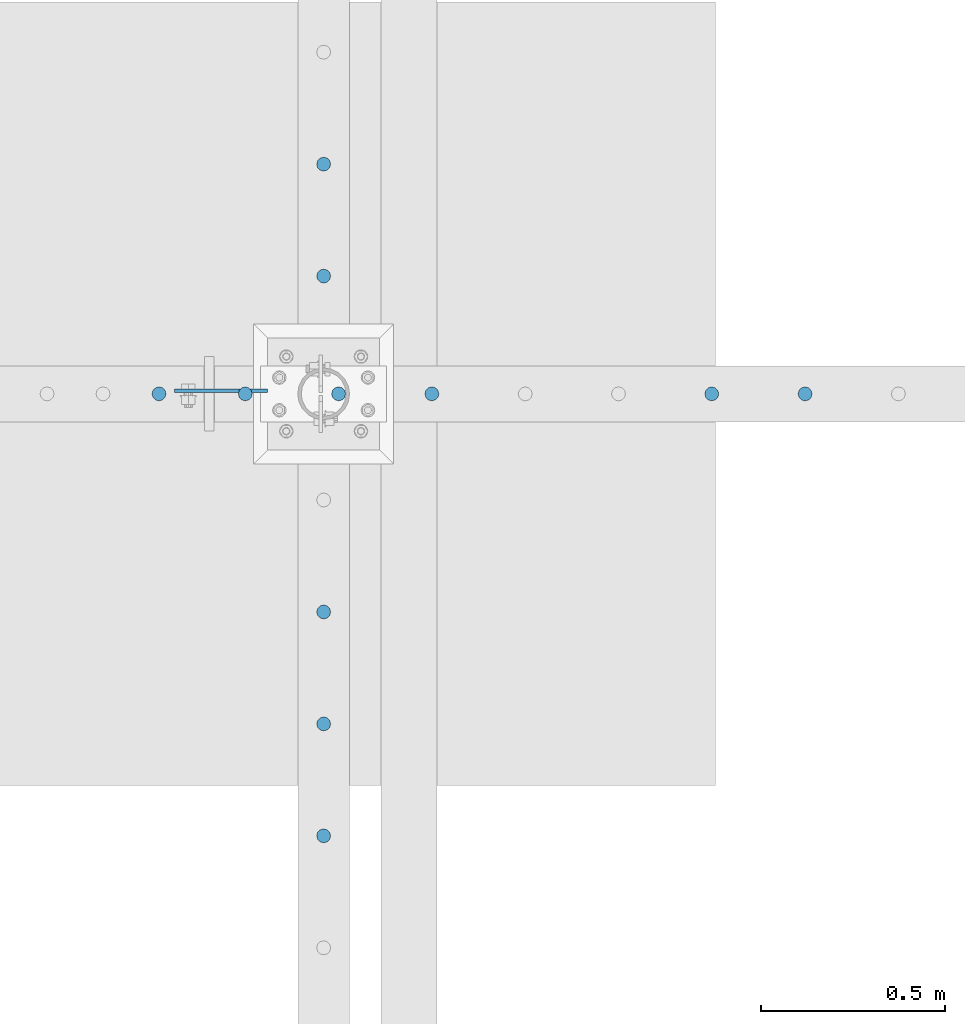
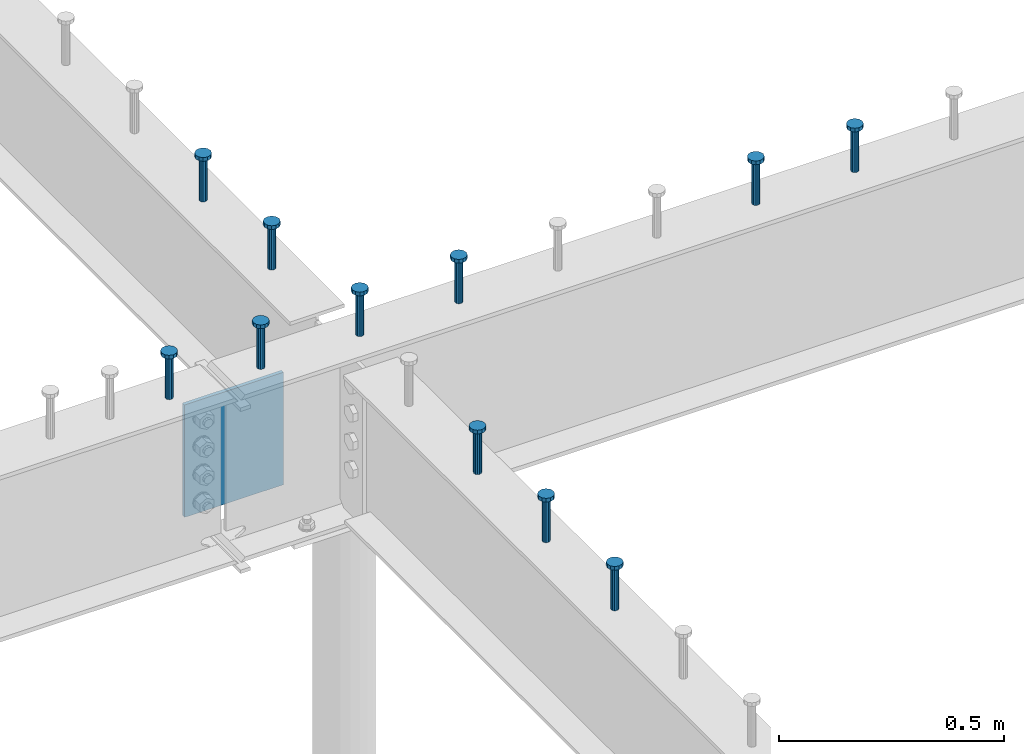
# One storey, part 165 of 975: 12 columns.
"""IFC2X3 building model written with IfcOpenShell, lengths in millimetres."""

import ifcopenshell
import ifcopenshell.guid

model = None  # the IFC model being written
_history = None  # IfcOwnerHistory: only IFC2X3 demands one
_inside = {}  # id of a spatial element -> (the spatial element, [elements in it])
_under = {}  # id of a project, library or spatial element -> (it, [spatial elements below it])
_declared = {}  # id of a project -> (the project, [libraries it declares])
_typed = {}  # id of a type object -> (the type object, [elements of that type])
_made_of = {}  # id of a material, layer set ... -> (it, [elements and type objects made of it])


def new_model(schema):
    """Start an empty IFC model of exactly this schema.

    Asked for "IFC4X3", IfcOpenShell would pick the latest addendum, in which some entities
    have other attributes; the version numbers below select the first issue.
    IFC2X3 requires an IfcOwnerHistory on every rooted entity: one is made here for all.
    """
    global model, _history
    if schema == "IFC4X3":
        model = ifcopenshell.file(schema_version=(4, 3, 0, 0))
    else:
        model = ifcopenshell.file(schema=schema)
    _inside.clear()
    _under.clear()
    _declared.clear()
    _typed.clear()
    _made_of.clear()
    _history = None
    if model.schema == "IFC2X3":
        org = make("IfcOrganization", Name="unknown")
        user = make(
            "IfcPersonAndOrganization",
            ThePerson=make("IfcPerson", FamilyName="unknown"),
            TheOrganization=org,
        )
        app = make(
            "IfcApplication",
            ApplicationDeveloper=org,
            Version="unknown",
            ApplicationFullName="unknown",
            ApplicationIdentifier="unknown",
        )
        _history = make(
            "IfcOwnerHistory",
            OwningUser=user,
            OwningApplication=app,
            ChangeAction="ADDED",
            CreationDate=0,
        )
    return model


def make(cls, **values):
    """One entity of the class cls with the attributes given. An attribute that is None is left unset."""
    return model.create_entity(
        cls, **{name: value for name, value in values.items() if value is not None}
    )


def rooted(cls, **values):
    """An entity with a GlobalId (a new one), such as an element, a storey or a relation."""
    return make(cls, GlobalId=ifcopenshell.guid.new(), OwnerHistory=_history, **values)


def si_unit(unit_type, name, prefix=None):
    """IfcSIUnit, for example si_unit("LENGTHUNIT", "METRE", prefix="MILLI")."""
    return make("IfcSIUnit", UnitType=unit_type, Prefix=prefix, Name=name)


def assignment(units):
    """IfcUnitAssignment: the units of a project."""
    return None if units is None else make("IfcUnitAssignment", Units=units)


def point(xyz):
    """IfcCartesianPoint."""
    return None if xyz is None else make("IfcCartesianPoint", Coordinates=xyz)


def direction(xyz):
    """IfcDirection."""
    return None if xyz is None else make("IfcDirection", DirectionRatios=xyz)


def frame(location, z_axis=None, x_axis=None):
    """IfcAxis2Placement3D, a coordinate frame: its origin and axes. An axis left out is left unset."""
    return make(
        "IfcAxis2Placement3D",
        Location=point(location),
        Axis=direction(z_axis),
        RefDirection=direction(x_axis),
    )


def origin_with_axes():
    """The frame at (0, 0, 0) with the z axis (0, 0, 1) and the x axis (1, 0, 0) written out."""
    return frame((0.0, 0.0, 0.0), z_axis=(0.0, 0.0, 1.0), x_axis=(1.0, 0.0, 0.0))


def place(relative_to, where):
    """IfcLocalPlacement: puts the frame where relative to a parent placement (None: the world)."""
    return make(
        "IfcLocalPlacement", PlacementRelTo=relative_to, RelativePlacement=where
    )


def context(
    kind, dimensions, precision=None, world=None, true_north=None, identifier=None
):
    """IfcGeometricRepresentationContext, for example the 3D "Model" context."""
    return make(
        "IfcGeometricRepresentationContext",
        ContextIdentifier=identifier,
        ContextType=kind,
        CoordinateSpaceDimension=dimensions,
        Precision=precision,
        WorldCoordinateSystem=world,
        TrueNorth=true_north,
    )


def subcontext(parent, identifier, kind, view, scale=None):
    """IfcGeometricRepresentationSubContext, for example "Body" below "Model"."""
    return make(
        "IfcGeometricRepresentationSubContext",
        ContextIdentifier=identifier,
        ContextType=kind,
        ParentContext=parent,
        TargetScale=scale,
        TargetView=view,
    )


def project(units=None, contexts=None):
    """IfcProject with its units and contexts."""
    return rooted(
        "IfcProject",
        Name="project",
        RepresentationContexts=contexts,
        UnitsInContext=assignment(units),
    )


def spatial(cls, under=None, at=None, **own):
    """A site, building, storey or space (cls), placed at a placement, below another one or the project."""
    s = rooted(cls, ObjectPlacement=at, **own)
    if under is not None:
        _under.setdefault(under.id(), (under, []))[1].append(s)
    return s


def faces_of(points, faces, orient=None, outer=None):
    """IfcFace entities. A face is a list of loops; a loop is a list of indices into points, from 0.

    orient and outer hold one flag for each loop. By default every Orientation is true, the
    first loop of a face is its IfcFaceOuterBound and the others are IfcFaceBound.
    """
    made = []
    for i, loops in enumerate(faces):
        bounds = []
        for j, loop in enumerate(loops):
            is_outer = j == 0 if outer is None else outer[i][j]
            bounds.append(
                make(
                    "IfcFaceOuterBound" if is_outer else "IfcFaceBound",
                    Bound=make("IfcPolyLoop", Polygon=[points[k] for k in loop]),
                    Orientation=True if orient is None else orient[i][j],
                )
            )
        made.append(make("IfcFace", Bounds=bounds))
    return made


def faceted_brep(points, faces, orient=None, outer=None, voids=None):
    """IfcFacetedBrep: a solid bounded by flat faces; with voids (closed shells), ...WithVoids."""
    shared = [point(p) for p in points]
    hull = make("IfcClosedShell", CfsFaces=faces_of(shared, faces, orient, outer))
    if voids is None:
        return make("IfcFacetedBrep", Outer=hull)
    return make(
        "IfcFacetedBrepWithVoids",
        Outer=hull,
        Voids=[
            make(cls, CfsFaces=faces_of(shared, fs, o, b)) for cls, fs, o, b in voids
        ],
    )


def shape(context_of_items, identifier, shape_type, items):
    """IfcShapeRepresentation: the items that make up one representation, for example the "Body"."""
    return make(
        "IfcShapeRepresentation",
        ContextOfItems=context_of_items,
        RepresentationIdentifier=identifier,
        RepresentationType=shape_type,
        Items=items,
    )


def material(Name=None, Category=None):
    """IfcMaterial."""
    return make("IfcMaterial", Name=Name, Category=Category)


def made_of(thing, what):
    """Note that an element or type object is made of a material, layer set ...; save() writes the relation."""
    if what is not None:
        _made_of.setdefault(what.id(), (what, []))[1].append(thing)
    return thing


def type_object(cls, material=None, **own):
    """A type object (cls), such as IfcWallType, which elements share."""
    return made_of(rooted(cls, **own), material)


def element(
    cls,
    number,
    at=None,
    inside=None,
    cuts=None,
    type_object=None,
    material=None,
    context=None,
    identifier="Body",
    shape_type=None,
    held_by="IfcProductDefinitionShape",
    body=None,
    shapes=None,
    **own,
):
    """One element of the class cls, such as IfcWall. Its Tag is "e" and its number.

    at: its placement. inside: the storey or other place that contains it. cuts: it is an
    opening in that element (IfcRelVoidsElement). A single representation is given by context,
    identifier, shape_type and body (its items); several are given by shapes. held_by: the class
    of the entity that holds the representations. save() writes the other relations.
    """
    e = rooted(cls, Tag="e%d" % number, ObjectPlacement=at, **own)
    if body is not None:
        shapes = [shape(context, identifier, shape_type, body)]
    if shapes is not None:
        e.Representation = make(held_by, Representations=shapes)
    if inside is not None:
        _inside.setdefault(inside.id(), (inside, []))[1].append(e)
    if cuts is not None:
        rooted(
            "IfcRelVoidsElement", RelatingBuildingElement=cuts, RelatedOpeningElement=e
        )
    if type_object is not None:
        _typed.setdefault(type_object.id(), (type_object, []))[1].append(e)
    return made_of(e, material)


def aggregate(whole, parts):
    """IfcRelAggregates: a whole, such as a stair, and the parts it consists of."""
    return rooted("IfcRelAggregates", RelatingObject=whole, RelatedObjects=parts)


def save(model, path):
    """Write the relations noted so far, then the file.

    IfcRelAggregates (storeys below a building ...), IfcRelContainedInSpatialStructure (elements
    in a storey), IfcRelDefinesByType, IfcRelAssociatesMaterial and IfcRelDeclares: one each for
    every whole, place, type object, material and project.
    """
    for whole, parts in _under.values():
        aggregate(whole, parts)
    for where, things in _inside.values():
        rooted(
            "IfcRelContainedInSpatialStructure",
            RelatedElements=things,
            RelatingStructure=where,
        )
    for kind, things in _typed.values():
        rooted("IfcRelDefinesByType", RelatedObjects=things, RelatingType=kind)
    for what, things in _made_of.values():
        rooted("IfcRelAssociatesMaterial", RelatedObjects=things, RelatingMaterial=what)
    for by, libraries in _declared.values():
        rooted("IfcRelDeclares", RelatingContext=by, RelatedDefinitions=libraries)
    model.write(path)


model = new_model("IFC2X3")

# Units and contexts
model_context = context("Model", 3, precision=1e-05, world=origin_with_axes())
body_context = subcontext(model_context, "Body", "Model", "MODEL_VIEW")
ifc_project = project(units=[si_unit("LENGTHUNIT", "METRE", prefix="MILLI"), si_unit("AREAUNIT", "SQUARE_METRE"), si_unit("VOLUMEUNIT", "CUBIC_METRE"), si_unit("MASSUNIT", "GRAM", prefix="KILO"), si_unit("TIMEUNIT", "SECOND"), si_unit("PLANEANGLEUNIT", "RADIAN"), si_unit("SOLIDANGLEUNIT", "STERADIAN"), si_unit("THERMODYNAMICTEMPERATUREUNIT", "DEGREE_CELSIUS"), si_unit("LUMINOUSINTENSITYUNIT", "LUMEN")], contexts=[model_context])

# Site, building, storey
site_placement = place(None, origin_with_axes())
site = spatial("IfcSite", under=ifc_project, at=site_placement, CompositionType="ELEMENT")
building_placement = place(site_placement, origin_with_axes())
building = spatial("IfcBuilding", under=site, at=building_placement, Name="Undefined", CompositionType="ELEMENT")
storey_placement = place(building_placement, origin_with_axes())
storey = spatial("IfcBuildingStorey", under=building, at=storey_placement, Name="Undefined", CompositionType="ELEMENT", Elevation=0.0)

# Columns
ifc_material_1 = material(Name="STEEL/A108")
column_type_1 = type_object("IfcColumnType", Name="STUD_3/4-DIA", PredefinedType="NOTDEFINED")
column_1_placement = place(storey_placement, frame((8229.66627141015, 14017.625, 3937.0), z_axis=(0.0, 1.0, 0.0), x_axis=(0.0, 0.0, 1.0)))
element("IfcColumn", 1, at=column_1_placement, inside=storey, type_object=column_type_1, material=ifc_material_1, ObjectType="STUD_3/4-DIA", context=body_context, shape_type="Brep", body=[
    faceted_brep([(0.0, -9.52000045776367, 0.0), (0.0, -8.25, -4.76000022888184), (115.57, -8.25, -4.76000022888184), (115.57, -9.52000045776367, 0.0), (0.0, -4.76000022888184, -8.25), (115.57, -4.76000022888184, -8.25), (0.0, 0.0, -9.52000045776367), (115.57, 0.0, -9.52000045776367), (0.0, 4.76000022888184, -8.25), (115.57, 4.76000022888184, -8.25), (0.0, 8.25, -4.76000022888184), (115.57, 8.25, -4.76000022888184), (0.0, 9.52000045776367, 0.0), (115.57, 9.52000045776367, 0.0), (0.0, 8.25, 4.76000022888184), (115.57, 8.25, 4.76000022888184), (0.0, 4.76000022888184, 8.25), (115.57, 4.76000022888184, 8.25), (0.0, 0.0, 9.52000045776367), (115.57, 0.0, 9.52000045776367), (0.0, -4.76000022888184, 8.25), (115.57, -4.76000022888184, 8.25), (0.0, -8.25, 4.76000022888184), (115.57, -8.25, 4.76000022888184), (116.84, -16.5, -9.52000045776367), (116.84, -19.0499992370605, 0.0), (116.84, -9.52000045776367, -16.5), (116.84, 0.0, -19.0499992370605), (116.84, 9.52000045776367, -16.5), (116.84, 16.5, -9.52000045776367), (116.84, 19.0499992370605, 0.0), (116.84, 16.5, 9.52000045776367), (116.84, 9.52000045776367, 16.5), (116.84, 0.0, 19.0499992370605), (116.84, -9.52000045776367, 16.5), (116.84, -16.5, 9.52000045776367), (127.0, -16.5, -9.52000045776367), (127.0, -19.0499992370605, 0.0), (127.0, -9.52000045776367, -16.5), (127.0, 0.0, -19.0499992370605), (127.0, 9.52000045776367, -16.5), (127.0, 16.5, -9.52000045776367), (127.0, 19.0499992370605, 0.0), (127.0, 16.5, 9.52000045776367), (127.0, 9.52000045776367, 16.5), (127.0, 0.0, 19.0499992370605), (127.0, -9.52000045776367, 16.5), (127.0, -16.5, 9.52000045776367)], [[[0, 1, 2, 3]], [[1, 4, 5, 2]], [[4, 6, 7, 5]], [[6, 8, 9, 7]], [[8, 10, 11, 9]], [[10, 12, 13, 11]], [[12, 14, 15, 13]], [[14, 16, 17, 15]], [[16, 18, 19, 17]], [[18, 20, 21, 19]], [[20, 22, 23, 21]], [[22, 0, 3, 23]], [[22, 20, 18, 16, 14, 12, 10, 8, 6, 4, 1, 0]], [[3, 2, 24, 25]], [[2, 5, 26, 24]], [[5, 7, 27, 26]], [[7, 9, 28, 27]], [[9, 11, 29, 28]], [[11, 13, 30, 29]], [[13, 15, 31, 30]], [[15, 17, 32, 31]], [[17, 19, 33, 32]], [[19, 21, 34, 33]], [[21, 23, 35, 34]], [[23, 3, 25, 35]], [[25, 24, 36, 37]], [[24, 26, 38, 36]], [[26, 27, 39, 38]], [[27, 28, 40, 39]], [[28, 29, 41, 40]], [[29, 30, 42, 41]], [[30, 31, 43, 42]], [[31, 32, 44, 43]], [[32, 33, 45, 44]], [[33, 34, 46, 45]], [[34, 35, 47, 46]], [[35, 25, 37, 47]], [[38, 39, 40, 41, 42, 43, 44, 45, 46, 47, 37, 36]]]),
])
column_2_placement = place(storey_placement, frame((8229.66627141015, 13712.825, 3937.0), z_axis=(0.0, 1.0, 0.0), x_axis=(0.0, 0.0, 1.0)))
element("IfcColumn", 2, at=column_2_placement, inside=storey, type_object=column_type_1, material=ifc_material_1, ObjectType="STUD_3/4-DIA", context=body_context, shape_type="Brep", body=[
    faceted_brep([(0.0, -9.52000045776367, 0.0), (0.0, -8.25, -4.76000022888184), (115.57, -8.25, -4.76000022888184), (115.57, -9.52000045776367, 0.0), (0.0, -4.76000022888184, -8.25), (115.57, -4.76000022888184, -8.25), (0.0, 0.0, -9.52000045776367), (115.57, 0.0, -9.52000045776367), (0.0, 4.76000022888184, -8.25), (115.57, 4.76000022888184, -8.25), (0.0, 8.25, -4.76000022888184), (115.57, 8.25, -4.76000022888184), (0.0, 9.52000045776367, 0.0), (115.57, 9.52000045776367, 0.0), (0.0, 8.25, 4.76000022888184), (115.57, 8.25, 4.76000022888184), (0.0, 4.76000022888184, 8.25), (115.57, 4.76000022888184, 8.25), (0.0, 0.0, 9.52000045776367), (115.57, 0.0, 9.52000045776367), (0.0, -4.76000022888184, 8.25), (115.57, -4.76000022888184, 8.25), (0.0, -8.25, 4.76000022888184), (115.57, -8.25, 4.76000022888184), (116.84, -16.5, -9.52000045776367), (116.84, -19.0499992370605, 0.0), (116.84, -9.52000045776367, -16.5), (116.84, 0.0, -19.0499992370605), (116.84, 9.52000045776367, -16.5), (116.84, 16.5, -9.52000045776367), (116.84, 19.0499992370605, 0.0), (116.84, 16.5, 9.52000045776367), (116.84, 9.52000045776367, 16.5), (116.84, 0.0, 19.0499992370605), (116.84, -9.52000045776367, 16.5), (116.84, -16.5, 9.52000045776367), (127.0, -16.5, -9.52000045776367), (127.0, -19.0499992370605, 0.0), (127.0, -9.52000045776367, -16.5), (127.0, 0.0, -19.0499992370605), (127.0, 9.52000045776367, -16.5), (127.0, 16.5, -9.52000045776367), (127.0, 19.0499992370605, 0.0), (127.0, 16.5, 9.52000045776367), (127.0, 9.52000045776367, 16.5), (127.0, 0.0, 19.0499992370605), (127.0, -9.52000045776367, 16.5), (127.0, -16.5, 9.52000045776367)], [[[0, 1, 2, 3]], [[1, 4, 5, 2]], [[4, 6, 7, 5]], [[6, 8, 9, 7]], [[8, 10, 11, 9]], [[10, 12, 13, 11]], [[12, 14, 15, 13]], [[14, 16, 17, 15]], [[16, 18, 19, 17]], [[18, 20, 21, 19]], [[20, 22, 23, 21]], [[22, 0, 3, 23]], [[22, 20, 18, 16, 14, 12, 10, 8, 6, 4, 1, 0]], [[3, 2, 24, 25]], [[2, 5, 26, 24]], [[5, 7, 27, 26]], [[7, 9, 28, 27]], [[9, 11, 29, 28]], [[11, 13, 30, 29]], [[13, 15, 31, 30]], [[15, 17, 32, 31]], [[17, 19, 33, 32]], [[19, 21, 34, 33]], [[21, 23, 35, 34]], [[23, 3, 25, 35]], [[25, 24, 36, 37]], [[24, 26, 38, 36]], [[26, 27, 39, 38]], [[27, 28, 40, 39]], [[28, 29, 41, 40]], [[29, 30, 42, 41]], [[30, 31, 43, 42]], [[31, 32, 44, 43]], [[32, 33, 45, 44]], [[33, 34, 46, 45]], [[34, 35, 47, 46]], [[35, 25, 37, 47]], [[38, 39, 40, 41, 42, 43, 44, 45, 46, 47, 37, 36]]]),
])
column_3_placement = place(storey_placement, frame((8229.66627141015, 12798.425, 3937.0), z_axis=(0.0, 1.0, 0.0), x_axis=(0.0, 0.0, 1.0)))
element("IfcColumn", 3, at=column_3_placement, inside=storey, type_object=column_type_1, material=ifc_material_1, ObjectType="STUD_3/4-DIA", context=body_context, shape_type="Brep", body=[
    faceted_brep([(0.0, -9.52000045776367, 0.0), (0.0, -8.25, -4.76000022888184), (115.57, -8.25, -4.76000022888184), (115.57, -9.52000045776367, 0.0), (0.0, -4.76000022888184, -8.25), (115.57, -4.76000022888184, -8.25), (0.0, 0.0, -9.52000045776367), (115.57, 0.0, -9.52000045776367), (0.0, 4.76000022888184, -8.25), (115.57, 4.76000022888184, -8.25), (0.0, 8.25, -4.76000022888184), (115.57, 8.25, -4.76000022888184), (0.0, 9.52000045776367, 0.0), (115.57, 9.52000045776367, 0.0), (0.0, 8.25, 4.76000022888184), (115.57, 8.25, 4.76000022888184), (0.0, 4.76000022888184, 8.25), (115.57, 4.76000022888184, 8.25), (0.0, 0.0, 9.52000045776367), (115.57, 0.0, 9.52000045776367), (0.0, -4.76000022888184, 8.25), (115.57, -4.76000022888184, 8.25), (0.0, -8.25, 4.76000022888184), (115.57, -8.25, 4.76000022888184), (116.84, -16.5, -9.52000045776367), (116.84, -19.0499992370605, 0.0), (116.84, -9.52000045776367, -16.5), (116.84, 0.0, -19.0499992370605), (116.84, 9.52000045776367, -16.5), (116.84, 16.5, -9.52000045776367), (116.84, 19.0499992370605, 0.0), (116.84, 16.5, 9.52000045776367), (116.84, 9.52000045776367, 16.5), (116.84, 0.0, 19.0499992370605), (116.84, -9.52000045776367, 16.5), (116.84, -16.5, 9.52000045776367), (127.0, -16.5, -9.52000045776367), (127.0, -19.0499992370605, 0.0), (127.0, -9.52000045776367, -16.5), (127.0, 0.0, -19.0499992370605), (127.0, 9.52000045776367, -16.5), (127.0, 16.5, -9.52000045776367), (127.0, 19.0499992370605, 0.0), (127.0, 16.5, 9.52000045776367), (127.0, 9.52000045776367, 16.5), (127.0, 0.0, 19.0499992370605), (127.0, -9.52000045776367, 16.5), (127.0, -16.5, 9.52000045776367)], [[[0, 1, 2, 3]], [[1, 4, 5, 2]], [[4, 6, 7, 5]], [[6, 8, 9, 7]], [[8, 10, 11, 9]], [[10, 12, 13, 11]], [[12, 14, 15, 13]], [[14, 16, 17, 15]], [[16, 18, 19, 17]], [[18, 20, 21, 19]], [[20, 22, 23, 21]], [[22, 0, 3, 23]], [[22, 20, 18, 16, 14, 12, 10, 8, 6, 4, 1, 0]], [[3, 2, 24, 25]], [[2, 5, 26, 24]], [[5, 7, 27, 26]], [[7, 9, 28, 27]], [[9, 11, 29, 28]], [[11, 13, 30, 29]], [[13, 15, 31, 30]], [[15, 17, 32, 31]], [[17, 19, 33, 32]], [[19, 21, 34, 33]], [[21, 23, 35, 34]], [[23, 3, 25, 35]], [[25, 24, 36, 37]], [[24, 26, 38, 36]], [[26, 27, 39, 38]], [[27, 28, 40, 39]], [[28, 29, 41, 40]], [[29, 30, 42, 41]], [[30, 31, 43, 42]], [[31, 32, 44, 43]], [[32, 33, 45, 44]], [[33, 34, 46, 45]], [[34, 35, 47, 46]], [[35, 25, 37, 47]], [[38, 39, 40, 41, 42, 43, 44, 45, 46, 47, 37, 36]]]),
])
column_4_placement = place(storey_placement, frame((8229.66627141015, 12493.625, 3937.0), z_axis=(0.0, 1.0, 0.0), x_axis=(0.0, 0.0, 1.0)))
element("IfcColumn", 4, at=column_4_placement, inside=storey, type_object=column_type_1, material=ifc_material_1, ObjectType="STUD_3/4-DIA", context=body_context, shape_type="Brep", body=[
    faceted_brep([(0.0, -9.52000045776367, 0.0), (0.0, -8.25, -4.76000022888184), (115.57, -8.25, -4.76000022888184), (115.57, -9.52000045776367, 0.0), (0.0, -4.76000022888184, -8.25), (115.57, -4.76000022888184, -8.25), (0.0, 0.0, -9.52000045776367), (115.57, 0.0, -9.52000045776367), (0.0, 4.76000022888184, -8.25), (115.57, 4.76000022888184, -8.25), (0.0, 8.25, -4.76000022888184), (115.57, 8.25, -4.76000022888184), (0.0, 9.52000045776367, 0.0), (115.57, 9.52000045776367, 0.0), (0.0, 8.25, 4.76000022888184), (115.57, 8.25, 4.76000022888184), (0.0, 4.76000022888184, 8.25), (115.57, 4.76000022888184, 8.25), (0.0, 0.0, 9.52000045776367), (115.57, 0.0, 9.52000045776367), (0.0, -4.76000022888184, 8.25), (115.57, -4.76000022888184, 8.25), (0.0, -8.25, 4.76000022888184), (115.57, -8.25, 4.76000022888184), (116.84, -16.5, -9.52000045776367), (116.84, -19.0499992370605, 0.0), (116.84, -9.52000045776367, -16.5), (116.84, 0.0, -19.0499992370605), (116.84, 9.52000045776367, -16.5), (116.84, 16.5, -9.52000045776367), (116.84, 19.0499992370605, 0.0), (116.84, 16.5, 9.52000045776367), (116.84, 9.52000045776367, 16.5), (116.84, 0.0, 19.0499992370605), (116.84, -9.52000045776367, 16.5), (116.84, -16.5, 9.52000045776367), (127.0, -16.5, -9.52000045776367), (127.0, -19.0499992370605, 0.0), (127.0, -9.52000045776367, -16.5), (127.0, 0.0, -19.0499992370605), (127.0, 9.52000045776367, -16.5), (127.0, 16.5, -9.52000045776367), (127.0, 19.0499992370605, 0.0), (127.0, 16.5, 9.52000045776367), (127.0, 9.52000045776367, 16.5), (127.0, 0.0, 19.0499992370605), (127.0, -9.52000045776367, 16.5), (127.0, -16.5, 9.52000045776367)], [[[0, 1, 2, 3]], [[1, 4, 5, 2]], [[4, 6, 7, 5]], [[6, 8, 9, 7]], [[8, 10, 11, 9]], [[10, 12, 13, 11]], [[12, 14, 15, 13]], [[14, 16, 17, 15]], [[16, 18, 19, 17]], [[18, 20, 21, 19]], [[20, 22, 23, 21]], [[22, 0, 3, 23]], [[22, 20, 18, 16, 14, 12, 10, 8, 6, 4, 1, 0]], [[3, 2, 24, 25]], [[2, 5, 26, 24]], [[5, 7, 27, 26]], [[7, 9, 28, 27]], [[9, 11, 29, 28]], [[11, 13, 30, 29]], [[13, 15, 31, 30]], [[15, 17, 32, 31]], [[17, 19, 33, 32]], [[19, 21, 34, 33]], [[21, 23, 35, 34]], [[23, 3, 25, 35]], [[25, 24, 36, 37]], [[24, 26, 38, 36]], [[26, 27, 39, 38]], [[27, 28, 40, 39]], [[28, 29, 41, 40]], [[29, 30, 42, 41]], [[30, 31, 43, 42]], [[31, 32, 44, 43]], [[32, 33, 45, 44]], [[33, 34, 46, 45]], [[34, 35, 47, 46]], [[35, 25, 37, 47]], [[38, 39, 40, 41, 42, 43, 44, 45, 46, 47, 37, 36]]]),
])
column_5_placement = place(storey_placement, frame((8229.66627141015, 12188.825, 3937.0), z_axis=(0.0, 1.0, 0.0), x_axis=(0.0, 0.0, 1.0)))
element("IfcColumn", 5, at=column_5_placement, inside=storey, type_object=column_type_1, material=ifc_material_1, ObjectType="STUD_3/4-DIA", context=body_context, shape_type="Brep", body=[
    faceted_brep([(0.0, -9.52000045776367, 0.0), (0.0, -8.25, -4.76000022888184), (115.57, -8.25, -4.76000022888184), (115.57, -9.52000045776367, 0.0), (0.0, -4.76000022888184, -8.25), (115.57, -4.76000022888184, -8.25), (0.0, 0.0, -9.52000045776367), (115.57, 0.0, -9.52000045776367), (0.0, 4.76000022888184, -8.25), (115.57, 4.76000022888184, -8.25), (0.0, 8.25, -4.76000022888184), (115.57, 8.25, -4.76000022888184), (0.0, 9.52000045776367, 0.0), (115.57, 9.52000045776367, 0.0), (0.0, 8.25, 4.76000022888184), (115.57, 8.25, 4.76000022888184), (0.0, 4.76000022888184, 8.25), (115.57, 4.76000022888184, 8.25), (0.0, 0.0, 9.52000045776367), (115.57, 0.0, 9.52000045776367), (0.0, -4.76000022888184, 8.25), (115.57, -4.76000022888184, 8.25), (0.0, -8.25, 4.76000022888184), (115.57, -8.25, 4.76000022888184), (116.84, -16.5, -9.52000045776367), (116.84, -19.0499992370605, 0.0), (116.84, -9.52000045776367, -16.5), (116.84, 0.0, -19.0499992370605), (116.84, 9.52000045776367, -16.5), (116.84, 16.5, -9.52000045776367), (116.84, 19.0499992370605, 0.0), (116.84, 16.5, 9.52000045776367), (116.84, 9.52000045776367, 16.5), (116.84, 0.0, 19.0499992370605), (116.84, -9.52000045776367, 16.5), (116.84, -16.5, 9.52000045776367), (127.0, -16.5, -9.52000045776367), (127.0, -19.0499992370605, 0.0), (127.0, -9.52000045776367, -16.5), (127.0, 0.0, -19.0499992370605), (127.0, 9.52000045776367, -16.5), (127.0, 16.5, -9.52000045776367), (127.0, 19.0499992370605, 0.0), (127.0, 16.5, 9.52000045776367), (127.0, 9.52000045776367, 16.5), (127.0, 0.0, 19.0499992370605), (127.0, -9.52000045776367, 16.5), (127.0, -16.5, 9.52000045776367)], [[[0, 1, 2, 3]], [[1, 4, 5, 2]], [[4, 6, 7, 5]], [[6, 8, 9, 7]], [[8, 10, 11, 9]], [[10, 12, 13, 11]], [[12, 14, 15, 13]], [[14, 16, 17, 15]], [[16, 18, 19, 17]], [[18, 20, 21, 19]], [[20, 22, 23, 21]], [[22, 0, 3, 23]], [[22, 20, 18, 16, 14, 12, 10, 8, 6, 4, 1, 0]], [[3, 2, 24, 25]], [[2, 5, 26, 24]], [[5, 7, 27, 26]], [[7, 9, 28, 27]], [[9, 11, 29, 28]], [[11, 13, 30, 29]], [[13, 15, 31, 30]], [[15, 17, 32, 31]], [[17, 19, 33, 32]], [[19, 21, 34, 33]], [[21, 23, 35, 34]], [[23, 3, 25, 35]], [[25, 24, 36, 37]], [[24, 26, 38, 36]], [[26, 27, 39, 38]], [[27, 28, 40, 39]], [[28, 29, 41, 40]], [[29, 30, 42, 41]], [[30, 31, 43, 42]], [[31, 32, 44, 43]], [[32, 33, 45, 44]], [[33, 34, 46, 45]], [[34, 35, 47, 46]], [[35, 25, 37, 47]], [[38, 39, 40, 41, 42, 43, 44, 45, 46, 47, 37, 36]]]),
])
column_6_placement = place(storey_placement, frame((9540.34595841014, 13392.15, 3937.0), z_axis=(0.0, 1.0, 0.0), x_axis=(0.0, 0.0, 1.0)))
element("IfcColumn", 6, at=column_6_placement, inside=storey, type_object=column_type_1, material=ifc_material_1, ObjectType="STUD_3/4-DIA", context=body_context, shape_type="Brep", body=[
    faceted_brep([(0.0, -9.52000045776367, 0.0), (0.0, -8.25, -4.76000022888184), (115.57, -8.25, -4.76000022888184), (115.57, -9.52000045776367, 0.0), (0.0, -4.76000022888184, -8.25), (115.57, -4.76000022888184, -8.25), (0.0, 0.0, -9.52000045776367), (115.57, 0.0, -9.52000045776367), (0.0, 4.76000022888184, -8.25), (115.57, 4.76000022888184, -8.25), (0.0, 8.25, -4.76000022888184), (115.57, 8.25, -4.76000022888184), (0.0, 9.52000045776367, 0.0), (115.57, 9.52000045776367, 0.0), (0.0, 8.25, 4.76000022888184), (115.57, 8.25, 4.76000022888184), (0.0, 4.76000022888184, 8.25), (115.57, 4.76000022888184, 8.25), (0.0, 0.0, 9.52000045776367), (115.57, 0.0, 9.52000045776367), (0.0, -4.76000022888184, 8.25), (115.57, -4.76000022888184, 8.25), (0.0, -8.25, 4.76000022888184), (115.57, -8.25, 4.76000022888184), (116.84, -16.5, -9.52000045776367), (116.84, -19.0499992370605, 0.0), (116.84, -9.52000045776367, -16.5), (116.84, 0.0, -19.0499992370605), (116.84, 9.52000045776367, -16.5), (116.84, 16.5, -9.52000045776367), (116.84, 19.0499992370605, 0.0), (116.84, 16.5, 9.52000045776367), (116.84, 9.52000045776367, 16.5), (116.84, 0.0, 19.0499992370605), (116.84, -9.52000045776367, 16.5), (116.84, -16.5, 9.52000045776367), (127.0, -16.5, -9.52000045776367), (127.0, -19.0499992370605, 0.0), (127.0, -9.52000045776367, -16.5), (127.0, 0.0, -19.0499992370605), (127.0, 9.52000045776367, -16.5), (127.0, 16.5, -9.52000045776367), (127.0, 19.0499992370605, 0.0), (127.0, 16.5, 9.52000045776367), (127.0, 9.52000045776367, 16.5), (127.0, 0.0, 19.0499992370605), (127.0, -9.52000045776367, 16.5), (127.0, -16.5, 9.52000045776367)], [[[0, 1, 2, 3]], [[1, 4, 5, 2]], [[4, 6, 7, 5]], [[6, 8, 9, 7]], [[8, 10, 11, 9]], [[10, 12, 13, 11]], [[12, 14, 15, 13]], [[14, 16, 17, 15]], [[16, 18, 19, 17]], [[18, 20, 21, 19]], [[20, 22, 23, 21]], [[22, 0, 3, 23]], [[22, 20, 18, 16, 14, 12, 10, 8, 6, 4, 1, 0]], [[3, 2, 24, 25]], [[2, 5, 26, 24]], [[5, 7, 27, 26]], [[7, 9, 28, 27]], [[9, 11, 29, 28]], [[11, 13, 30, 29]], [[13, 15, 31, 30]], [[15, 17, 32, 31]], [[17, 19, 33, 32]], [[19, 21, 34, 33]], [[21, 23, 35, 34]], [[23, 3, 25, 35]], [[25, 24, 36, 37]], [[24, 26, 38, 36]], [[26, 27, 39, 38]], [[27, 28, 40, 39]], [[28, 29, 41, 40]], [[29, 30, 42, 41]], [[30, 31, 43, 42]], [[31, 32, 44, 43]], [[32, 33, 45, 44]], [[33, 34, 46, 45]], [[34, 35, 47, 46]], [[35, 25, 37, 47]], [[38, 39, 40, 41, 42, 43, 44, 45, 46, 47, 37, 36]]]),
])
column_7_placement = place(storey_placement, frame((9286.34595841014, 13392.15, 3937.0), z_axis=(0.0, 1.0, 0.0), x_axis=(0.0, 0.0, 1.0)))
element("IfcColumn", 7, at=column_7_placement, inside=storey, type_object=column_type_1, material=ifc_material_1, ObjectType="STUD_3/4-DIA", context=body_context, shape_type="Brep", body=[
    faceted_brep([(0.0, -9.52000045776367, 0.0), (0.0, -8.25, -4.76000022888184), (115.57, -8.25, -4.76000022888184), (115.57, -9.52000045776367, 0.0), (0.0, -4.76000022888184, -8.25), (115.57, -4.76000022888184, -8.25), (0.0, 0.0, -9.52000045776367), (115.57, 0.0, -9.52000045776367), (0.0, 4.76000022888184, -8.25), (115.57, 4.76000022888184, -8.25), (0.0, 8.25, -4.76000022888184), (115.57, 8.25, -4.76000022888184), (0.0, 9.52000045776367, 0.0), (115.57, 9.52000045776367, 0.0), (0.0, 8.25, 4.76000022888184), (115.57, 8.25, 4.76000022888184), (0.0, 4.76000022888184, 8.25), (115.57, 4.76000022888184, 8.25), (0.0, 0.0, 9.52000045776367), (115.57, 0.0, 9.52000045776367), (0.0, -4.76000022888184, 8.25), (115.57, -4.76000022888184, 8.25), (0.0, -8.25, 4.76000022888184), (115.57, -8.25, 4.76000022888184), (116.84, -16.5, -9.52000045776367), (116.84, -19.0499992370605, 0.0), (116.84, -9.52000045776367, -16.5), (116.84, 0.0, -19.0499992370605), (116.84, 9.52000045776367, -16.5), (116.84, 16.5, -9.52000045776367), (116.84, 19.0499992370605, 0.0), (116.84, 16.5, 9.52000045776367), (116.84, 9.52000045776367, 16.5), (116.84, 0.0, 19.0499992370605), (116.84, -9.52000045776367, 16.5), (116.84, -16.5, 9.52000045776367), (127.0, -16.5, -9.52000045776367), (127.0, -19.0499992370605, 0.0), (127.0, -9.52000045776367, -16.5), (127.0, 0.0, -19.0499992370605), (127.0, 9.52000045776367, -16.5), (127.0, 16.5, -9.52000045776367), (127.0, 19.0499992370605, 0.0), (127.0, 16.5, 9.52000045776367), (127.0, 9.52000045776367, 16.5), (127.0, 0.0, 19.0499992370605), (127.0, -9.52000045776367, 16.5), (127.0, -16.5, 9.52000045776367)], [[[0, 1, 2, 3]], [[1, 4, 5, 2]], [[4, 6, 7, 5]], [[6, 8, 9, 7]], [[8, 10, 11, 9]], [[10, 12, 13, 11]], [[12, 14, 15, 13]], [[14, 16, 17, 15]], [[16, 18, 19, 17]], [[18, 20, 21, 19]], [[20, 22, 23, 21]], [[22, 0, 3, 23]], [[22, 20, 18, 16, 14, 12, 10, 8, 6, 4, 1, 0]], [[3, 2, 24, 25]], [[2, 5, 26, 24]], [[5, 7, 27, 26]], [[7, 9, 28, 27]], [[9, 11, 29, 28]], [[11, 13, 30, 29]], [[13, 15, 31, 30]], [[15, 17, 32, 31]], [[17, 19, 33, 32]], [[19, 21, 34, 33]], [[21, 23, 35, 34]], [[23, 3, 25, 35]], [[25, 24, 36, 37]], [[24, 26, 38, 36]], [[26, 27, 39, 38]], [[27, 28, 40, 39]], [[28, 29, 41, 40]], [[29, 30, 42, 41]], [[30, 31, 43, 42]], [[31, 32, 44, 43]], [[32, 33, 45, 44]], [[33, 34, 46, 45]], [[34, 35, 47, 46]], [[35, 25, 37, 47]], [[38, 39, 40, 41, 42, 43, 44, 45, 46, 47, 37, 36]]]),
])
column_8_placement = place(storey_placement, frame((8524.34595841014, 13392.15, 3937.0), z_axis=(0.0, 1.0, 0.0), x_axis=(0.0, 0.0, 1.0)))
element("IfcColumn", 8, at=column_8_placement, inside=storey, type_object=column_type_1, material=ifc_material_1, ObjectType="STUD_3/4-DIA", context=body_context, shape_type="Brep", body=[
    faceted_brep([(0.0, -9.52000045776367, 0.0), (0.0, -8.25, -4.76000022888184), (115.57, -8.25, -4.76000022888184), (115.57, -9.52000045776367, 0.0), (0.0, -4.76000022888184, -8.25), (115.57, -4.76000022888184, -8.25), (0.0, 0.0, -9.52000045776367), (115.57, 0.0, -9.52000045776367), (0.0, 4.76000022888184, -8.25), (115.57, 4.76000022888184, -8.25), (0.0, 8.25, -4.76000022888184), (115.57, 8.25, -4.76000022888184), (0.0, 9.52000045776367, 0.0), (115.57, 9.52000045776367, 0.0), (0.0, 8.25, 4.76000022888184), (115.57, 8.25, 4.76000022888184), (0.0, 4.76000022888184, 8.25), (115.57, 4.76000022888184, 8.25), (0.0, 0.0, 9.52000045776367), (115.57, 0.0, 9.52000045776367), (0.0, -4.76000022888184, 8.25), (115.57, -4.76000022888184, 8.25), (0.0, -8.25, 4.76000022888184), (115.57, -8.25, 4.76000022888184), (116.84, -16.5, -9.52000045776367), (116.84, -19.0499992370605, 0.0), (116.84, -9.52000045776367, -16.5), (116.84, 0.0, -19.0499992370605), (116.84, 9.52000045776367, -16.5), (116.84, 16.5, -9.52000045776367), (116.84, 19.0499992370605, 0.0), (116.84, 16.5, 9.52000045776367), (116.84, 9.52000045776367, 16.5), (116.84, 0.0, 19.0499992370605), (116.84, -9.52000045776367, 16.5), (116.84, -16.5, 9.52000045776367), (127.0, -16.5, -9.52000045776367), (127.0, -19.0499992370605, 0.0), (127.0, -9.52000045776367, -16.5), (127.0, 0.0, -19.0499992370605), (127.0, 9.52000045776367, -16.5), (127.0, 16.5, -9.52000045776367), (127.0, 19.0499992370605, 0.0), (127.0, 16.5, 9.52000045776367), (127.0, 9.52000045776367, 16.5), (127.0, 0.0, 19.0499992370605), (127.0, -9.52000045776367, 16.5), (127.0, -16.5, 9.52000045776367)], [[[0, 1, 2, 3]], [[1, 4, 5, 2]], [[4, 6, 7, 5]], [[6, 8, 9, 7]], [[8, 10, 11, 9]], [[10, 12, 13, 11]], [[12, 14, 15, 13]], [[14, 16, 17, 15]], [[16, 18, 19, 17]], [[18, 20, 21, 19]], [[20, 22, 23, 21]], [[22, 0, 3, 23]], [[22, 20, 18, 16, 14, 12, 10, 8, 6, 4, 1, 0]], [[3, 2, 24, 25]], [[2, 5, 26, 24]], [[5, 7, 27, 26]], [[7, 9, 28, 27]], [[9, 11, 29, 28]], [[11, 13, 30, 29]], [[13, 15, 31, 30]], [[15, 17, 32, 31]], [[17, 19, 33, 32]], [[19, 21, 34, 33]], [[21, 23, 35, 34]], [[23, 3, 25, 35]], [[25, 24, 36, 37]], [[24, 26, 38, 36]], [[26, 27, 39, 38]], [[27, 28, 40, 39]], [[28, 29, 41, 40]], [[29, 30, 42, 41]], [[30, 31, 43, 42]], [[31, 32, 44, 43]], [[32, 33, 45, 44]], [[33, 34, 46, 45]], [[34, 35, 47, 46]], [[35, 25, 37, 47]], [[38, 39, 40, 41, 42, 43, 44, 45, 46, 47, 37, 36]]]),
])
column_9_placement = place(storey_placement, frame((8270.34595841014, 13392.15, 3937.0), z_axis=(0.0, 1.0, 0.0), x_axis=(0.0, 0.0, 1.0)))
element("IfcColumn", 9, at=column_9_placement, inside=storey, type_object=column_type_1, material=ifc_material_1, ObjectType="STUD_3/4-DIA", context=body_context, shape_type="Brep", body=[
    faceted_brep([(0.0, -9.52000045776367, 0.0), (0.0, -8.25, -4.76000022888184), (115.57, -8.25, -4.76000022888184), (115.57, -9.52000045776367, 0.0), (0.0, -4.76000022888184, -8.25), (115.57, -4.76000022888184, -8.25), (0.0, 0.0, -9.52000045776367), (115.57, 0.0, -9.52000045776367), (0.0, 4.76000022888184, -8.25), (115.57, 4.76000022888184, -8.25), (0.0, 8.25, -4.76000022888184), (115.57, 8.25, -4.76000022888184), (0.0, 9.52000045776367, 0.0), (115.57, 9.52000045776367, 0.0), (0.0, 8.25, 4.76000022888184), (115.57, 8.25, 4.76000022888184), (0.0, 4.76000022888184, 8.25), (115.57, 4.76000022888184, 8.25), (0.0, 0.0, 9.52000045776367), (115.57, 0.0, 9.52000045776367), (0.0, -4.76000022888184, 8.25), (115.57, -4.76000022888184, 8.25), (0.0, -8.25, 4.76000022888184), (115.57, -8.25, 4.76000022888184), (116.84, -16.5, -9.52000045776367), (116.84, -19.0499992370605, 0.0), (116.84, -9.52000045776367, -16.5), (116.84, 0.0, -19.0499992370605), (116.84, 9.52000045776367, -16.5), (116.84, 16.5, -9.52000045776367), (116.84, 19.0499992370605, 0.0), (116.84, 16.5, 9.52000045776367), (116.84, 9.52000045776367, 16.5), (116.84, 0.0, 19.0499992370605), (116.84, -9.52000045776367, 16.5), (116.84, -16.5, 9.52000045776367), (127.0, -16.5, -9.52000045776367), (127.0, -19.0499992370605, 0.0), (127.0, -9.52000045776367, -16.5), (127.0, 0.0, -19.0499992370605), (127.0, 9.52000045776367, -16.5), (127.0, 16.5, -9.52000045776367), (127.0, 19.0499992370605, 0.0), (127.0, 16.5, 9.52000045776367), (127.0, 9.52000045776367, 16.5), (127.0, 0.0, 19.0499992370605), (127.0, -9.52000045776367, 16.5), (127.0, -16.5, 9.52000045776367)], [[[0, 1, 2, 3]], [[1, 4, 5, 2]], [[4, 6, 7, 5]], [[6, 8, 9, 7]], [[8, 10, 11, 9]], [[10, 12, 13, 11]], [[12, 14, 15, 13]], [[14, 16, 17, 15]], [[16, 18, 19, 17]], [[18, 20, 21, 19]], [[20, 22, 23, 21]], [[22, 0, 3, 23]], [[22, 20, 18, 16, 14, 12, 10, 8, 6, 4, 1, 0]], [[3, 2, 24, 25]], [[2, 5, 26, 24]], [[5, 7, 27, 26]], [[7, 9, 28, 27]], [[9, 11, 29, 28]], [[11, 13, 30, 29]], [[13, 15, 31, 30]], [[15, 17, 32, 31]], [[17, 19, 33, 32]], [[19, 21, 34, 33]], [[21, 23, 35, 34]], [[23, 3, 25, 35]], [[25, 24, 36, 37]], [[24, 26, 38, 36]], [[26, 27, 39, 38]], [[27, 28, 40, 39]], [[28, 29, 41, 40]], [[29, 30, 42, 41]], [[30, 31, 43, 42]], [[31, 32, 44, 43]], [[32, 33, 45, 44]], [[33, 34, 46, 45]], [[34, 35, 47, 46]], [[35, 25, 37, 47]], [[38, 39, 40, 41, 42, 43, 44, 45, 46, 47, 37, 36]]]),
])
column_10_placement = place(storey_placement, frame((7781.39595841014, 13392.15, 3937.0), z_axis=(0.0, 1.0, 0.0), x_axis=(0.0, 0.0, 1.0)))
element("IfcColumn", 10, at=column_10_placement, inside=storey, type_object=column_type_1, material=ifc_material_1, ObjectType="STUD_3/4-DIA", context=body_context, shape_type="Brep", body=[
    faceted_brep([(0.0, -9.52000045776367, 0.0), (0.0, -8.25, -4.76000022888184), (115.57, -8.25, -4.76000022888184), (115.57, -9.52000045776367, 0.0), (0.0, -4.76000022888184, -8.25), (115.57, -4.76000022888184, -8.25), (0.0, 0.0, -9.52000045776367), (115.57, 0.0, -9.52000045776367), (0.0, 4.76000022888184, -8.25), (115.57, 4.76000022888184, -8.25), (0.0, 8.25, -4.76000022888184), (115.57, 8.25, -4.76000022888184), (0.0, 9.52000045776367, 0.0), (115.57, 9.52000045776367, 0.0), (0.0, 8.25, 4.76000022888184), (115.57, 8.25, 4.76000022888184), (0.0, 4.76000022888184, 8.25), (115.57, 4.76000022888184, 8.25), (0.0, 0.0, 9.52000045776367), (115.57, 0.0, 9.52000045776367), (0.0, -4.76000022888184, 8.25), (115.57, -4.76000022888184, 8.25), (0.0, -8.25, 4.76000022888184), (115.57, -8.25, 4.76000022888184), (116.84, -16.5, -9.52000045776367), (116.84, -19.0499992370605, 0.0), (116.84, -9.52000045776367, -16.5), (116.84, 0.0, -19.0499992370605), (116.84, 9.52000045776367, -16.5), (116.84, 16.5, -9.52000045776367), (116.84, 19.0499992370605, 0.0), (116.84, 16.5, 9.52000045776367), (116.84, 9.52000045776367, 16.5), (116.84, 0.0, 19.0499992370605), (116.84, -9.52000045776367, 16.5), (116.84, -16.5, 9.52000045776367), (127.0, -16.5, -9.52000045776367), (127.0, -19.0499992370605, 0.0), (127.0, -9.52000045776367, -16.5), (127.0, 0.0, -19.0499992370605), (127.0, 9.52000045776367, -16.5), (127.0, 16.5, -9.52000045776367), (127.0, 19.0499992370605, 0.0), (127.0, 16.5, 9.52000045776367), (127.0, 9.52000045776367, 16.5), (127.0, 0.0, 19.0499992370605), (127.0, -9.52000045776367, 16.5), (127.0, -16.5, 9.52000045776367)], [[[0, 1, 2, 3]], [[1, 4, 5, 2]], [[4, 6, 7, 5]], [[6, 8, 9, 7]], [[8, 10, 11, 9]], [[10, 12, 13, 11]], [[12, 14, 15, 13]], [[14, 16, 17, 15]], [[16, 18, 19, 17]], [[18, 20, 21, 19]], [[20, 22, 23, 21]], [[22, 0, 3, 23]], [[22, 20, 18, 16, 14, 12, 10, 8, 6, 4, 1, 0]], [[3, 2, 24, 25]], [[2, 5, 26, 24]], [[5, 7, 27, 26]], [[7, 9, 28, 27]], [[9, 11, 29, 28]], [[11, 13, 30, 29]], [[13, 15, 31, 30]], [[15, 17, 32, 31]], [[17, 19, 33, 32]], [[19, 21, 34, 33]], [[21, 23, 35, 34]], [[23, 3, 25, 35]], [[25, 24, 36, 37]], [[24, 26, 38, 36]], [[26, 27, 39, 38]], [[27, 28, 40, 39]], [[28, 29, 41, 40]], [[29, 30, 42, 41]], [[30, 31, 43, 42]], [[31, 32, 44, 43]], [[32, 33, 45, 44]], [[33, 34, 46, 45]], [[34, 35, 47, 46]], [[35, 25, 37, 47]], [[38, 39, 40, 41, 42, 43, 44, 45, 46, 47, 37, 36]]]),
])
column_11_placement = place(storey_placement, frame((8016.34595841014, 13392.15, 3937.0), z_axis=(0.0, 1.0, 0.0), x_axis=(0.0, 0.0, 1.0)))
element("IfcColumn", 11, at=column_11_placement, inside=storey, type_object=column_type_1, material=ifc_material_1, ObjectType="STUD_3/4-DIA", context=body_context, shape_type="Brep", body=[
    faceted_brep([(0.0, -9.52000045776367, 0.0), (0.0, -8.25, -4.76000022888184), (115.57, -8.25, -4.76000022888184), (115.57, -9.52000045776367, 0.0), (0.0, -4.76000022888184, -8.25), (115.57, -4.76000022888184, -8.25), (0.0, 0.0, -9.52000045776367), (115.57, 0.0, -9.52000045776367), (0.0, 4.76000022888184, -8.25), (115.57, 4.76000022888184, -8.25), (0.0, 8.25, -4.76000022888184), (115.57, 8.25, -4.76000022888184), (0.0, 9.52000045776367, 0.0), (115.57, 9.52000045776367, 0.0), (0.0, 8.25, 4.76000022888184), (115.57, 8.25, 4.76000022888184), (0.0, 4.76000022888184, 8.25), (115.57, 4.76000022888184, 8.25), (0.0, 0.0, 9.52000045776367), (115.57, 0.0, 9.52000045776367), (0.0, -4.76000022888184, 8.25), (115.57, -4.76000022888184, 8.25), (0.0, -8.25, 4.76000022888184), (115.57, -8.25, 4.76000022888184), (116.84, -16.5, -9.52000045776367), (116.84, -19.0499992370605, 0.0), (116.84, -9.52000045776367, -16.5), (116.84, 0.0, -19.0499992370605), (116.84, 9.52000045776367, -16.5), (116.84, 16.5, -9.52000045776367), (116.84, 19.0499992370605, 0.0), (116.84, 16.5, 9.52000045776367), (116.84, 9.52000045776367, 16.5), (116.84, 0.0, 19.0499992370605), (116.84, -9.52000045776367, 16.5), (116.84, -16.5, 9.52000045776367), (127.0, -16.5, -9.52000045776367), (127.0, -19.0499992370605, 0.0), (127.0, -9.52000045776367, -16.5), (127.0, 0.0, -19.0499992370605), (127.0, 9.52000045776367, -16.5), (127.0, 16.5, -9.52000045776367), (127.0, 19.0499992370605, 0.0), (127.0, 16.5, 9.52000045776367), (127.0, 9.52000045776367, 16.5), (127.0, 0.0, 19.0499992370605), (127.0, -9.52000045776367, 16.5), (127.0, -16.5, 9.52000045776367)], [[[0, 1, 2, 3]], [[1, 4, 5, 2]], [[4, 6, 7, 5]], [[6, 8, 9, 7]], [[8, 10, 11, 9]], [[10, 12, 13, 11]], [[12, 14, 15, 13]], [[14, 16, 17, 15]], [[16, 18, 19, 17]], [[18, 20, 21, 19]], [[20, 22, 23, 21]], [[22, 0, 3, 23]], [[22, 20, 18, 16, 14, 12, 10, 8, 6, 4, 1, 0]], [[3, 2, 24, 25]], [[2, 5, 26, 24]], [[5, 7, 27, 26]], [[7, 9, 28, 27]], [[9, 11, 29, 28]], [[11, 13, 30, 29]], [[13, 15, 31, 30]], [[15, 17, 32, 31]], [[17, 19, 33, 32]], [[19, 21, 34, 33]], [[21, 23, 35, 34]], [[23, 3, 25, 35]], [[25, 24, 36, 37]], [[24, 26, 38, 36]], [[26, 27, 39, 38]], [[27, 28, 40, 39]], [[28, 29, 41, 40]], [[29, 30, 42, 41]], [[30, 31, 43, 42]], [[31, 32, 44, 43]], [[32, 33, 45, 44]], [[33, 34, 46, 45]], [[34, 35, 47, 46]], [[35, 25, 37, 47]], [[38, 39, 40, 41, 42, 43, 44, 45, 46, 47, 37, 36]]]),
])
ifc_material_2 = material(Name="STEEL/A36")
column_type_2 = type_object("IfcColumnType", PredefinedType="NOTDEFINED")
column_12_placement = place(storey_placement, frame((7950.2, 13400.8809999466, 3594.1), z_axis=(1.0, 0.0, 0.0), x_axis=(0.0, 0.0, 1.0)))
element("IfcColumn", 12, at=column_12_placement, inside=storey, type_object=column_type_2, material=ifc_material_2, Name="PLATE", context=body_context, shape_type="Brep", body=[
    faceted_brep([(0.0, 4.76250000000073, -127.0), (2.26333322643768e-05, 4.76250000029177, 127.000000000276), (304.8, 4.76250000000073, 127.0), (304.8, 4.76250000000073, -127.0), (2.26333322643768e-05, -4.76249999968422, 127.000000000295), (304.8, -4.76250000000073, 127.0), (0.0, -4.76250000000073, -127.0), (304.8, -4.76250000000073, -127.0)], [[[0, 1, 2, 3]], [[1, 4, 5, 2]], [[4, 6, 7, 5]], [[6, 0, 3, 7]], [[5, 7, 3, 2]], [[6, 4, 1, 0]]]),
])

save(model, "model.ifc")
